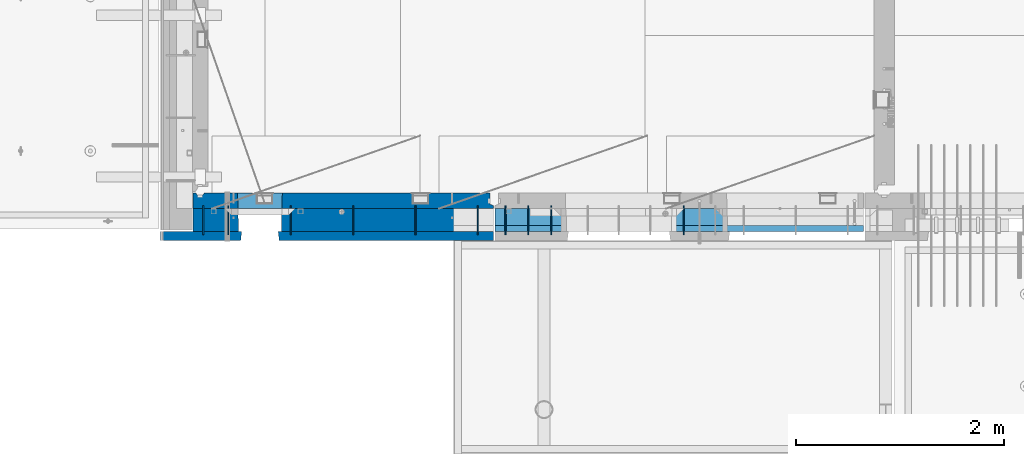
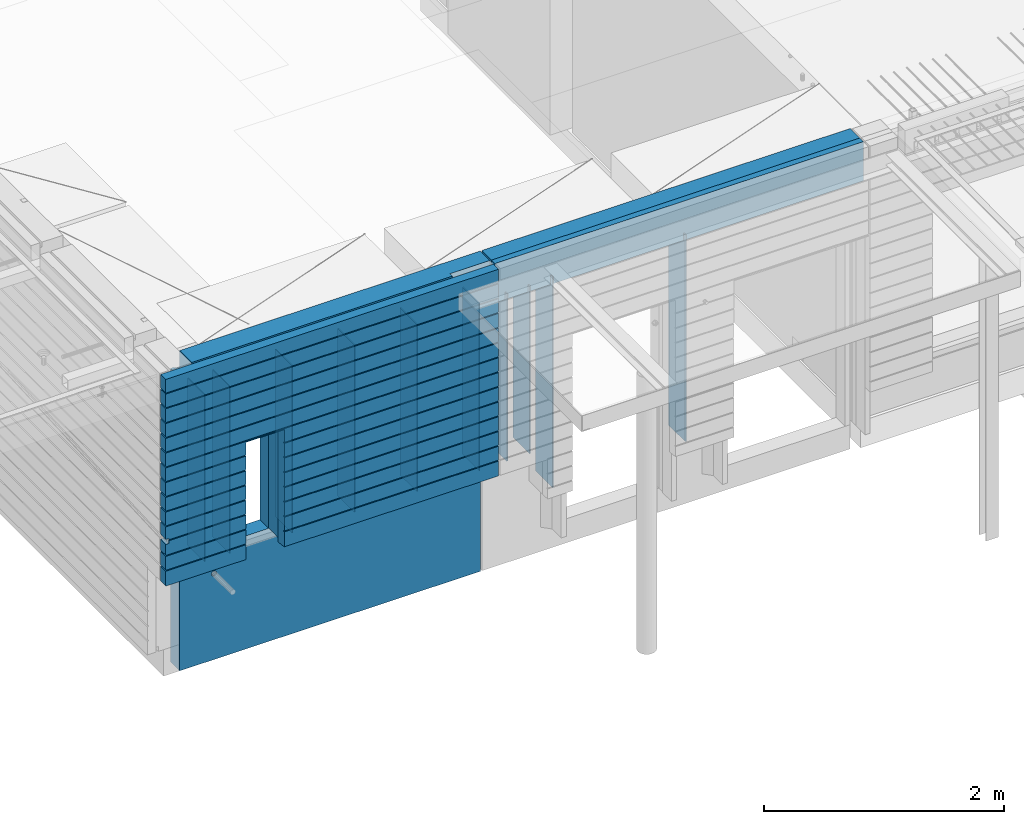
# One storey, part 206 of 325: 15 walls, 2 elements without a shape of their own.
"""IFC2X3 building model written with IfcOpenShell, lengths in millimetres."""

from ifc_helpers import new_model, si_unit, frame, origin_with_axes, place, context, subcontext, project, spatial, faceted_brep, material, type_object, element, aggregate, save


model = new_model("IFC2X3")

# Units and contexts
model_context = context("Model", 3, precision=1e-05, world=origin_with_axes())
body_context = subcontext(model_context, "Body", "Model", "MODEL_VIEW")
ifc_project = project(units=[si_unit("LENGTHUNIT", "METRE", prefix="MILLI"), si_unit("AREAUNIT", "SQUARE_METRE"), si_unit("VOLUMEUNIT", "CUBIC_METRE"), si_unit("MASSUNIT", "GRAM", prefix="KILO"), si_unit("TIMEUNIT", "SECOND"), si_unit("PLANEANGLEUNIT", "RADIAN"), si_unit("SOLIDANGLEUNIT", "STERADIAN"), si_unit("THERMODYNAMICTEMPERATUREUNIT", "DEGREE_CELSIUS"), si_unit("LUMINOUSINTENSITYUNIT", "LUMEN")], contexts=[model_context])

# Site, building, storey
site_placement = place(None, origin_with_axes())
site = spatial("IfcSite", under=ifc_project, at=site_placement, CompositionType="ELEMENT")
building_placement = place(site_placement, origin_with_axes())
building = spatial("IfcBuilding", under=site, at=building_placement, CompositionType="ELEMENT")
storey_placement = place(building_placement, origin_with_axes())
storey = spatial("IfcBuildingStorey", under=building, at=storey_placement, Name="1", CompositionType="ELEMENT", Elevation=0.0)

# Assembly, walls
assembly_1_placement = place(storey_placement, origin_with_axes())
assembly_1 = element("IfcElementAssembly", 1, at=assembly_1_placement, inside=storey, AssemblyPlace="NOTDEFINED", PredefinedType="REINFORCEMENT_UNIT")
ifc_material_1 = material(Name="COS5gt")
wall_type_1 = type_object("IfcWallType", PredefinedType="NOTDEFINED")
wall_1_placement = place(assembly_1_placement, frame((12912.5, 7740.0, 83247.5), z_axis=(0.0, 0.0, 1.0), x_axis=(-1.0, 3.00000001838171e-08, 0.0)))
wall_1 = element("IfcWall", 2, at=wall_1_placement, type_object=wall_type_1, material=ifc_material_1, context=body_context, shape_type="Brep", body=[
    faceted_brep([(392.500000000033, 90.0, 1492.5), (392.500000000033, 90.0, 1442.5), (392.500000000033, 110.0, 1442.5), (392.500000000033, 109.999999999999, 1092.50000000003), (392.500000000033, 49.9999999999991, 1092.50000000003), (392.500000000033, 49.9999999999991, 1492.50000000003), (7.50000000000728, 49.9999999999991, 1092.50000000003), (7.5, 110.0, 1092.50000000003), (7.50000000000728, 49.9999999999991, 1492.50000000003), (7.5, 90.0, -557.5), (2046.95893598611, 90.0, -557.5), (2046.95893598611, 90.0, -607.5), (7.5, 90.0, -607.5), (7.5, 110.0, -557.5), (2047.49947652665, 110.0, -557.5), (2897.5, 110.0, -557.5), (2897.5, 90.0, -557.5), (2458.04001706719, 90.0, -557.5), (2457.49947652665, 110.0, -557.5), (2897.5, 110.0, 1442.5), (2897.5, 90.0, 1442.5), (2897.5, 90.0, 1492.5), (2897.5, -110.0, 1492.5), (2897.5, -110.0, -607.5), (2897.5, 90.0, -607.5), (2458.04001706719, 90.0, -607.5), (2463.4454224726, -110.0, -607.5), (2463.4454224726, -110.0, 613.445945945947), (2457.49947652665, 110.0, 607.5), (2041.5535305807, -110.0, 613.445945945947), (2047.49947652665, 110.0, 607.5), (2041.5535305807, -110.0, -607.5), (7.5, -110.0, -607.5), (7.5, -110.0, 1492.5)], [[[0, 1, 2, 3, 4, 5]], [[6, 4, 3, 7]], [[8, 5, 4, 6]], [[9, 10, 11, 12]], [[9, 13, 14, 10]], [[15, 16, 17, 18]], [[16, 15, 19, 20, 21, 22, 23, 24]], [[17, 16, 24, 25]], [[23, 26, 25, 24]], [[27, 28, 18, 17, 25, 26]], [[29, 30, 28, 27]], [[10, 14, 30, 29, 31, 11]], [[11, 31, 32, 12]], [[29, 27, 26, 23, 22, 33, 32, 31]], [[7, 13, 9, 12, 32, 33, 8, 6]], [[2, 19, 15, 18, 28, 30, 14, 13, 7, 3]], [[20, 19, 2, 1]], [[21, 20, 1, 0]], [[33, 22, 21, 0, 5, 8]]]),
])
ifc_material_2 = material(Name="CONCRETE/C30/37")
wall_type_2 = type_object("IfcWallType", PredefinedType="NOTDEFINED")
wall_2_placement = place(assembly_1_placement, frame((12912.5, 7587.5, 83247.5), z_axis=(0.0, 0.0, 1.0), x_axis=(-1.0, 3.00000001838171e-08, 0.0)))
wall_2 = element("IfcWall", 3, at=wall_2_placement, type_object=wall_type_2, material=ifc_material_2, context=body_context, shape_type="Brep", body=[
    faceted_brep([(3207.5, -42.5, -179.98166420919), (3207.5, 42.5, -184.134200770088), (3177.5, 42.499873713009, -184.134200770088), (3177.5, -42.5, -179.98166420919), (3177.5, -42.5, -129.982527140222), (3177.5, 42.4999217833592, -134.134203897454), (3207.5, 42.5, -134.134203897454), (3207.5, -42.5, -129.982527140222), (3177.5, 42.5, -157.000000055239), (3177.5, 32.4999992501671, -155.000000000786), (3177.5, 32.4999991121649, -144.999999599575), (3177.5, 42.5, -143.000000110755), (7.4999999999709, 42.5, -457.000000055239), (2067.49947652665, 42.5, -457.000000055239), (2067.49947652665, 42.5, -607.5), (7.4999999999709, 42.5, -607.5), (7.49999999997817, 32.4999992501671, -455.000000000786), (2068.6759472031, 32.4999992501671, -455.000000000786), (7.49999999997817, 32.4999991121649, -444.999999599575), (2068.67594721934, 32.4999991121649, -444.999999599575), (7.4999999999709, 42.5, -443.000000110755), (2067.49947652665, 42.5, -443.000000110755), (7.4999999999709, 42.5, -307.000000055239), (2067.49947652665, 42.5, -307.000000055239), (7.4999999999709, 32.4999992501671, -305.000000000786), (2068.6759472031, 32.4999992501671, -305.000000000786), (7.4999999999709, 32.4999991121604, -294.999999599575), (2068.67594721934, 32.4999991121649, -294.999999599575), (7.4999999999709, 42.5, -293.000000110755), (2067.49947652665, 42.5, -293.000000110755), (7.4999999999709, 42.5, -157.000000055239), (2067.49947652665, 42.5, -157.000000055239), (7.49999999998181, 32.4999992501671, -155.000000000786), (2068.6759472031, 32.4999992501671, -155.000000000786), (7.49999999998181, 32.4999991121649, -144.999999599575), (2068.67594721934, 32.4999991121649, -144.999999599575), (7.4999999999709, 42.5, -143.000000110755), (2067.49947652665, 42.5, -143.000000110755), (7.4999999999709, 42.5, -7.00000005523907), (2067.49947652665, 42.5, -7.00000005523907), (7.4999999999709, 32.4999992501671, -5.0000000007858), (2068.6759472031, 32.4999992501671, -5.0000000007858), (7.4999999999709, 32.4999991121604, 5.00000040042505), (2068.67594721934, 32.4999991121649, 5.00000040042505), (7.4999999999709, 42.5, 6.99999988924537), (2067.49947652665, 42.5, 6.99999988924537), (7.4999999999709, 42.5, 142.999999944761), (2067.49947652665, 42.5, 142.999999944761), (7.49999999998545, 32.4999992501671, 144.999999999214), (2068.6759472031, 32.4999992501671, 144.999999999214), (7.49999999998545, 32.4999991121649, 155.000000400425), (2068.67594721934, 32.4999991121649, 155.000000400425), (7.4999999999709, 42.5, 156.999999889245), (2067.49947652665, 42.5, 156.999999889245), (7.4999999999709, 42.5, 292.999999944761), (2067.49947652665, 42.5, 292.999999944761), (7.49999999997453, 32.4999992501671, 294.999999999214), (2068.6759472031, 32.4999992501671, 294.999999999214), (7.49999999997453, 32.4999991121604, 305.000000400425), (2068.67594721934, 32.4999991121649, 305.000000400425), (7.4999999999709, 42.5, 306.999999889245), (2067.49947652665, 42.5, 306.999999889245), (7.4999999999709, 42.5, 442.999999944761), (2067.49947652665, 42.5, 442.999999944761), (7.49999999998545, 32.4999992501671, 444.999999999214), (2068.6759472031, 32.4999992501671, 444.999999999214), (7.49999999998545, 32.4999991121649, 455.000000400425), (2068.67594721934, 32.4999991121649, 455.000000400425), (7.4999999999709, 42.5, 456.999999889245), (2067.49947652665, 42.5, 456.999999889245), (7.4999999999709, 42.5, 1492.5), (3207.5, 42.5, 1492.5), (3207.5, 42.5, 1356.99999988925), (7.4999999999709, 42.5, 1356.99999988925), (7.49999999998909, 32.4999991121649, 1355.00000040043), (3197.4999991143, 32.4999991121649, 1355.00000040043), (7.49999999998909, 32.4999992501671, 1344.99999999921), (3197.4999992523, 32.4999992501671, 1344.99999999921), (7.4999999999709, 42.5, 1342.99999994476), (3207.5, 42.5, 1342.99999994476), (3207.5, 42.5, 1206.99999988925), (7.4999999999709, 42.5, 1206.99999988925), (7.49999999998363, 32.4999991121604, 1205.00000040043), (3197.49999897767, 32.4999991121604, 1205.00000040043), (7.49999999998363, 32.4999992501671, 1194.99999999921), (3197.49999925687, 32.4999992501671, 1194.99999999921), (7.4999999999709, 42.5, 1192.99999994476), (3207.5, 42.5, 1192.99999994476), (3207.5, 42.5, 1056.99999988925), (7.4999999999709, 42.5, 1056.99999988925), (7.49999999998727, 32.4999991121649, 1055.00000040043), (3197.4999991143, 32.4999991121649, 1055.00000040043), (7.49999999998727, 32.4999992501671, 1044.99999999921), (3197.4999992523, 32.4999992501671, 1044.99999999921), (7.4999999999709, 42.5, 1042.99999994476), (3207.5, 42.5, 1042.99999994476), (3207.5, 42.5, 906.999999889245), (7.4999999999709, 42.5, 906.999999889245), (7.49999999998181, 32.4999991121604, 905.000000400425), (3197.49999897767, 32.4999991121604, 905.000000400425), (7.49999999998181, 32.4999992501671, 894.999999999214), (3197.49999925687, 32.4999992501671, 894.999999999214), (7.4999999999709, 42.5, 892.999999944761), (3207.5, 42.5, 892.999999944761), (3207.5, 42.5, 756.999999889245), (7.4999999999709, 42.5, 756.999999889245), (7.49999999998727, 32.4999991121649, 755.000000400425), (3197.4999991143, 32.4999991121649, 755.000000400425), (7.49999999998727, 32.4999992501671, 744.999999999214), (3197.4999992523, 32.4999992501671, 744.999999999214), (7.4999999999709, 42.5, 742.999999944761), (3207.5, 42.5, 742.999999944761), (3207.5, 42.5, 606.999999889245), (7.4999999999709, 42.5, 606.999999889245), (7.49999999997999, 32.4999991121604, 605.000000400425), (3197.49999897767, 32.4999991121604, 605.000000400425), (7.49999999997999, 32.4999992501671, 594.999999999214), (3197.49999925687, 32.4999992501671, 594.999999999214), (7.4999999999709, 42.5, 592.999999944761), (3207.5, 42.5, 592.999999944761), (3207.5, 42.5, 456.999999889245), (2437.49947652665, 42.5, 456.999999889245), (2437.49947652665, 42.5, 582.5), (2427.49947652665, 42.5, 582.5), (2077.49947652665, 42.5, 582.5), (2067.49947652665, 42.5, 582.5), (2436.32300583397, 32.4999991121649, 455.000000400425), (3197.4999991143, 32.4999991121649, 455.000000400425), (2436.3230058502, 32.4999992501671, 444.999999999214), (3197.4999992523, 32.4999992501671, 444.999999999214), (2437.49947652665, 42.5, 442.999999944761), (3207.5, 42.5, 442.999999944761), (3207.5, 42.5, 306.999999889245), (2437.49947652665, 42.5, 306.999999889245), (2436.32300583397, 32.4999991121649, 305.000000400425), (3197.49999897767, 32.4999991121604, 305.000000400425), (2436.3230058502, 32.4999992501671, 294.999999999214), (3197.49999925687, 32.4999992501671, 294.999999999214), (2437.49947652665, 42.5, 292.999999944761), (3207.5, 42.5, 292.999999944761), (3207.5, 42.5, 156.999999889245), (2437.49947652665, 42.5, 156.999999889245), (2436.32300583397, 32.4999991121649, 155.000000400425), (3197.4999991143, 32.4999991121649, 155.000000400425), (2436.3230058502, 32.4999992501671, 144.999999999214), (3197.4999992523, 32.4999992501671, 144.999999999214), (2437.49947652665, 42.5, 142.999999944761), (3207.5, 42.5, 142.999999944761), (3207.5, 42.5, 6.99999988924537), (2437.49947652665, 42.5, 6.99999988924537), (2436.32300583397, 32.4999991121649, 5.00000040042505), (3197.49999897767, 32.4999991121604, 5.00000040042505), (2436.3230058502, 32.4999992501671, -5.0000000007858), (3197.49999925687, 32.4999992501671, -5.0000000007858), (2437.49947652665, 42.5, -7.00000005523907), (3207.5, 42.5, -7.00000005523907), (2437.49947652665, 42.5, -457.000000055239), (3207.5, 42.5, -457.000000055239), (3207.5, 42.5, -607.5), (2437.49947652665, 42.5, -607.5), (2436.3230058502, 32.4999992501671, -455.000000000786), (3197.4999992523, 32.4999992501671, -455.000000000786), (2436.32300583397, 32.4999991121649, -444.999999599575), (3197.4999991143, 32.4999991121649, -444.999999599575), (2437.49947652665, 42.5, -443.000000110755), (3207.5, 42.5, -443.000000110755), (3207.5, 42.5, -307.000000055239), (2437.49947652665, 42.5, -307.000000055239), (2436.3230058502, 32.4999992501671, -305.000000000786), (3197.49999925687, 32.4999992501671, -305.000000000786), (2436.32300583397, 32.4999991121649, -294.999999599575), (3197.49999897767, 32.4999991121604, -294.999999599575), (2437.49947652665, 42.5, -293.000000110755), (3207.5, 42.5, -293.000000110755), (3197.49999368253, -42.5, -294.999998542233), (3207.5, -42.5, -292.999998912201), (3197.49999396174, -42.5, -304.999998943444), (3207.5, -42.5, -306.9999988567), (3207.5, -42.5, -443.00000011074), (3197.4999991143, -42.5, -444.999999599546), (3197.4999992523, -42.5, -455.000000000771), (3207.5, -42.5, -457.000000055225), (3207.5, -42.5, -607.5), (2427.49947652665, -42.5, -607.5), (2427.49947652665, -42.5, 582.5), (2427.49947652665, -42.5, 587.5), (2437.49947652665, 42.5, -143.000000110755), (2436.32300583397, 32.4999991121649, -144.999999599575), (2436.3230058502, 32.4999992501671, -155.000000000786), (2437.49947652665, 42.5, -157.000000055239), (2077.49947652665, -42.5, 587.5), (2077.49947652665, -42.5, 582.5), (2077.49947652665, -42.5, -607.5), (7.4999999999709, -42.5, -607.5), (7.4999999999709, -42.5, 1492.5), (3207.5, -42.5, 1492.5), (3207.5, -42.5, 1356.99999988926), (3197.4999991143, -42.5, 1355.00000040045), (3197.4999992523, -42.5, 1344.99999999923), (3207.5, -42.5, 1342.99999994478), (3207.5, -42.5, 1207.0000010878), (3197.49999368253, -42.5, 1205.00000145777), (3197.49999396174, -42.5, 1195.00000105656), (3207.5, -42.5, 1193.0000011433), (3207.5, -42.5, 1056.99999988926), (3197.4999991143, -42.5, 1055.00000040045), (3197.4999992523, -42.5, 1044.99999999923), (3207.5, -42.5, 1042.99999994478), (3207.5, -42.5, 907.000001087799), (3197.49999368253, -42.5, 905.000001457767), (3197.49999396174, -42.5, 895.000001056556), (3207.5, -42.5, 893.0000011433), (3207.5, -42.5, 756.99999988926), (3197.4999991143, -42.5, 755.000000400454), (3197.4999992523, -42.5, 744.999999999229), (3207.5, -42.5, 742.999999944775), (3207.5, -42.5, 607.000001087799), (3197.49999368253, -42.5, 605.000001457767), (3197.49999396174, -42.5, 595.000001056556), (3207.5, -42.5, 593.0000011433), (3207.5, -42.5, 456.99999988926), (3197.4999991143, -42.5, 455.000000400454), (3197.4999992523, -42.5, 444.999999999229), (3207.5, -42.5, 442.999999944775), (3207.5, -42.5, 307.000001087799), (3197.49999368253, -42.5, 305.000001457767), (3197.49999396174, -42.5, 295.000001056556), (3207.5, -42.5, 293.0000011433), (3207.5, -42.5, 156.99999988926), (3197.4999991143, -42.5, 155.000000400454), (3197.4999992523, -42.5, 144.999999999229), (3207.5, -42.5, 142.999999944775), (3207.5, -42.5, 7.00000108779932), (3197.49999368253, -42.5, 5.00000145776721), (3197.49999396174, -42.5, -4.99999894344364), (3207.5, -42.5, -6.99999885669968)], [[[0, 1, 2, 3]], [[4, 5, 6, 7]], [[3, 2, 8, 9, 10, 11, 5, 4]], [[12, 13, 14, 15]], [[12, 16, 17, 13]], [[16, 18, 19, 17]], [[18, 20, 21, 19]], [[20, 22, 23, 21]], [[22, 24, 25, 23]], [[24, 26, 27, 25]], [[26, 28, 29, 27]], [[28, 30, 31, 29]], [[30, 32, 33, 31]], [[32, 34, 35, 33]], [[34, 36, 37, 35]], [[36, 38, 39, 37]], [[38, 40, 41, 39]], [[40, 42, 43, 41]], [[42, 44, 45, 43]], [[44, 46, 47, 45]], [[46, 48, 49, 47]], [[48, 50, 51, 49]], [[50, 52, 53, 51]], [[52, 54, 55, 53]], [[54, 56, 57, 55]], [[56, 58, 59, 57]], [[58, 60, 61, 59]], [[60, 62, 63, 61]], [[62, 64, 65, 63]], [[64, 66, 67, 65]], [[66, 68, 69, 67]], [[70, 71, 72, 73]], [[74, 73, 72, 75]], [[76, 74, 75, 77]], [[78, 76, 77, 79]], [[80, 81, 78, 79]], [[82, 81, 80, 83]], [[84, 82, 83, 85]], [[86, 84, 85, 87]], [[86, 87, 88, 89]], [[90, 89, 88, 91]], [[92, 90, 91, 93]], [[94, 92, 93, 95]], [[96, 97, 94, 95]], [[98, 97, 96, 99]], [[100, 98, 99, 101]], [[102, 100, 101, 103]], [[102, 103, 104, 105]], [[106, 105, 104, 107]], [[108, 106, 107, 109]], [[110, 108, 109, 111]], [[112, 113, 110, 111]], [[114, 113, 112, 115]], [[116, 114, 115, 117]], [[118, 116, 117, 119]], [[68, 118, 119, 120, 121, 122, 123, 124, 125, 69]], [[126, 121, 120, 127]], [[128, 126, 127, 129]], [[130, 128, 129, 131]], [[131, 132, 133, 130]], [[134, 133, 132, 135]], [[136, 134, 135, 137]], [[138, 136, 137, 139]], [[139, 140, 141, 138]], [[142, 141, 140, 143]], [[144, 142, 143, 145]], [[146, 144, 145, 147]], [[147, 148, 149, 146]], [[150, 149, 148, 151]], [[152, 150, 151, 153]], [[154, 152, 153, 155]], [[156, 157, 158, 159]], [[156, 160, 161, 157]], [[160, 162, 163, 161]], [[162, 164, 165, 163]], [[166, 165, 164, 167]], [[167, 168, 169, 166]], [[168, 170, 171, 169]], [[170, 172, 173, 171]], [[174, 171, 173, 175]], [[176, 169, 171, 174]], [[177, 166, 169, 176]], [[178, 165, 166, 177]], [[179, 163, 165, 178]], [[180, 161, 163, 179]], [[181, 157, 161, 180]], [[182, 158, 157, 181]], [[158, 182, 183, 159]], [[184, 185, 122, 121, 126, 128, 130, 133, 134, 136, 138, 141, 142, 144, 146, 149, 150, 152, 154, 186, 187, 188, 189, 172, 170, 168, 167, 164, 162, 160, 156, 159, 183]], [[124, 123, 122, 185, 190, 125]], [[13, 17, 19, 21, 23, 25, 27, 29, 31, 33, 35, 37, 39, 41, 43, 45, 47, 49, 51, 53, 55, 57, 59, 61, 63, 65, 67, 69, 125, 190, 191, 192, 14]], [[14, 192, 193, 15]], [[194, 70, 73, 74, 76, 78, 81, 82, 84, 86, 89, 90, 92, 94, 97, 98, 100, 102, 105, 106, 108, 110, 113, 114, 116, 118, 68, 66, 64, 62, 60, 58, 56, 54, 52, 50, 48, 46, 44, 42, 40, 38, 36, 34, 32, 30, 28, 26, 24, 22, 20, 18, 16, 12, 15, 193]], [[70, 194, 195, 71]], [[71, 195, 196, 72]], [[197, 75, 72, 196]], [[198, 77, 75, 197]], [[199, 79, 77, 198]], [[200, 80, 79, 199]], [[201, 83, 80, 200]], [[202, 85, 83, 201]], [[203, 87, 85, 202]], [[204, 88, 87, 203]], [[205, 91, 88, 204]], [[206, 93, 91, 205]], [[207, 95, 93, 206]], [[208, 96, 95, 207]], [[209, 99, 96, 208]], [[210, 101, 99, 209]], [[211, 103, 101, 210]], [[212, 104, 103, 211]], [[213, 107, 104, 212]], [[214, 109, 107, 213]], [[215, 111, 109, 214]], [[216, 112, 111, 215]], [[217, 115, 112, 216]], [[218, 117, 115, 217]], [[219, 119, 117, 218]], [[220, 120, 119, 219]], [[221, 127, 120, 220]], [[222, 129, 127, 221]], [[223, 131, 129, 222]], [[224, 132, 131, 223]], [[225, 135, 132, 224]], [[226, 137, 135, 225]], [[227, 139, 137, 226]], [[228, 140, 139, 227]], [[229, 143, 140, 228]], [[230, 145, 143, 229]], [[231, 147, 145, 230]], [[232, 148, 147, 231]], [[233, 151, 148, 232]], [[234, 153, 151, 233]], [[235, 155, 153, 234]], [[155, 235, 7, 6]], [[186, 154, 155, 6, 5, 11]], [[187, 186, 11, 10]], [[188, 187, 10, 9]], [[189, 188, 9, 8]], [[1, 173, 172, 189, 8, 2]], [[175, 173, 1, 0]], [[235, 234, 233, 232, 231, 230, 229, 228, 227, 226, 225, 224, 223, 222, 221, 220, 219, 218, 217, 216, 215, 214, 213, 212, 211, 210, 209, 208, 207, 206, 205, 204, 203, 202, 201, 200, 199, 198, 197, 196, 195, 194, 193, 192, 191, 190, 185, 184, 183, 182, 181, 180, 179, 178, 177, 176, 174, 175, 0, 3, 4, 7]]]),
])

assembly_2_placement = place(storey_placement, origin_with_axes())
assembly_2 = element("IfcElementAssembly", 4, at=assembly_2_placement, inside=storey, AssemblyPlace="NOTDEFINED", PredefinedType="REINFORCEMENT_UNIT")
ifc_material_3 = material(Name="Undefined")
wall_type_3 = type_object("IfcWallType", PredefinedType="NOTDEFINED")
wall_3_placement = place(assembly_2_placement, frame((13460.0, 7880.0, 83365.0), z_axis=(0.0, 0.0, 1.0), x_axis=(0.0, -1.0, 0.0)))
wall_3 = element("IfcWall", 5, at=wall_3_placement, type_object=wall_type_3, material=ifc_material_3, Name="(PD)", context=body_context, shape_type="Brep", body=[
    faceted_brep([(0.0, 5.0, -1070.0), (0.0, 5.0, 1070.0), (280.0, 5.0, 1070.0), (280.0, 5.0, -1070.0), (0.0, -5.0, 1070.0), (280.0, -5.0, 1070.0), (0.0, -5.0, -1070.0), (280.0, -5.0, -1070.0)], [[[0, 1, 2, 3]], [[1, 4, 5, 2]], [[4, 6, 7, 5]], [[6, 0, 3, 7]], [[5, 7, 3, 2]], [[6, 4, 1, 0]]]),
])
wall_type_4 = type_object("IfcWallType", PredefinedType="NOTDEFINED")
wall_4_placement = place(assembly_2_placement, frame((13240.0, 7880.0, 83565.0), z_axis=(0.0, 0.0, 1.0), x_axis=(0.0, -1.0, 0.0)))
wall_4 = element("IfcWall", 6, at=wall_4_placement, type_object=wall_type_4, material=ifc_material_3, Name="(PD)", context=body_context, shape_type="Brep", body=[
    faceted_brep([(0.0, 5.0, -850.0), (0.0, 5.0, 850.0), (280.0, 5.0, 850.0), (280.0, 5.0, -850.0), (0.0, -5.0, 850.0), (280.0, -5.0, 850.0), (0.0, -5.0, -850.0), (280.0, -5.0, -850.0)], [[[0, 1, 2, 3]], [[1, 4, 5, 2]], [[4, 6, 7, 5]], [[6, 0, 3, 7]], [[5, 7, 3, 2]], [[6, 4, 1, 0]]]),
])

# Wall
wall_5_placement = place(assembly_1_placement, frame((10115.0, 7880.0, 83560.0), z_axis=(0.0, 0.0, 1.0), x_axis=(0.0, -1.0, 0.0)))
wall_5 = element("IfcWall", 7, at=wall_5_placement, type_object=wall_type_4, material=ifc_material_3, Name="(PD)", context=body_context, shape_type="Brep", body=[
    faceted_brep([(0.0, 5.0, -850.0), (0.0, 5.0, 850.0), (280.0, 5.0, 850.0), (280.0, 5.0, -850.0), (0.0, -5.0, 850.0), (280.0, -5.0, 850.0), (0.0, -5.0, -850.0), (280.0, -5.0, -850.0)], [[[0, 1, 2, 3]], [[1, 4, 5, 2]], [[4, 6, 7, 5]], [[6, 0, 3, 7]], [[5, 7, 3, 2]], [[6, 4, 1, 0]]]),
])

wall_6_placement = place(assembly_1_placement, frame((10355.0, 7880.0, 83560.0), z_axis=(0.0, 0.0, 1.0), x_axis=(0.0, -1.0, 0.0)))
wall_6 = element("IfcWall", 8, at=wall_6_placement, type_object=wall_type_4, material=ifc_material_3, Name="(PD)", context=body_context, shape_type="Brep", body=[
    faceted_brep([(0.0, 5.0, -850.0), (0.0, 5.0, 850.0), (280.0, 5.0, 850.0), (280.0, 5.0, -850.0), (0.0, -5.0, 850.0), (280.0, -5.0, 850.0), (0.0, -5.0, -850.0), (280.0, -5.0, -850.0)], [[[0, 1, 2, 3]], [[1, 4, 5, 2]], [[4, 6, 7, 5]], [[6, 0, 3, 7]], [[5, 7, 3, 2]], [[6, 4, 1, 0]]]),
])

wall_7_placement = place(assembly_1_placement, frame((10955.0, 7880.0, 83560.0), z_axis=(0.0, 0.0, 1.0), x_axis=(0.0, -1.0, 0.0)))
wall_7 = element("IfcWall", 9, at=wall_7_placement, type_object=wall_type_4, material=ifc_material_3, Name="(PD)", context=body_context, shape_type="Brep", body=[
    faceted_brep([(0.0, 5.0, -850.0), (0.0, 5.0, 850.0), (280.0, 5.0, 850.0), (280.0, 5.0, -850.0), (0.0, -5.0, 850.0), (280.0, -5.0, 850.0), (0.0, -5.0, -850.0), (280.0, -5.0, -850.0)], [[[0, 1, 2, 3]], [[1, 4, 5, 2]], [[4, 6, 7, 5]], [[6, 0, 3, 7]], [[5, 7, 3, 2]], [[6, 4, 1, 0]]]),
])

wall_8_placement = place(assembly_1_placement, frame((11555.0, 7880.0, 83560.0), z_axis=(0.0, 0.0, 1.0), x_axis=(0.0, -1.0, 0.0)))
wall_8 = element("IfcWall", 10, at=wall_8_placement, type_object=wall_type_4, material=ifc_material_3, Name="(PD)", context=body_context, shape_type="Brep", body=[
    faceted_brep([(0.0, 5.0, -850.0), (0.0, 5.0, 850.0), (280.0, 5.0, 850.0), (280.0, 5.0, -850.0), (0.0, -5.0, 850.0), (280.0, -5.0, 850.0), (0.0, -5.0, -850.0), (280.0, -5.0, -850.0)], [[[0, 1, 2, 3]], [[1, 4, 5, 2]], [[4, 6, 7, 5]], [[6, 0, 3, 7]], [[5, 7, 3, 2]], [[6, 4, 1, 0]]]),
])

wall_9_placement = place(assembly_1_placement, frame((12155.0, 7880.0, 83560.0), z_axis=(0.0, 0.0, 1.0), x_axis=(0.0, -1.0, 0.0)))
wall_9 = element("IfcWall", 11, at=wall_9_placement, type_object=wall_type_4, material=ifc_material_3, Name="(PD)", context=body_context, shape_type="Brep", body=[
    faceted_brep([(0.0, 5.0, -850.0), (0.0, 5.0, 850.0), (280.0, 5.0, 850.0), (280.0, 5.0, -850.0), (0.0, -5.0, 850.0), (280.0, -5.0, 850.0), (0.0, -5.0, -850.0), (280.0, -5.0, -850.0)], [[[0, 1, 2, 3]], [[1, 4, 5, 2]], [[4, 6, 7, 5]], [[6, 0, 3, 7]], [[5, 7, 3, 2]], [[6, 4, 1, 0]]]),
])

wall_10_placement = place(assembly_2_placement, frame((13020.0, 7880.0, 83565.0), z_axis=(0.0, 0.0, 1.0), x_axis=(0.0, -1.0, 0.0)))
wall_10 = element("IfcWall", 12, at=wall_10_placement, type_object=wall_type_4, material=ifc_material_3, Name="(PD)", context=body_context, shape_type="Brep", body=[
    faceted_brep([(0.0, 5.0, -850.0), (0.0, 5.0, 850.0), (280.0, 5.0, 850.0), (280.0, 5.0, -850.0), (0.0, -5.0, 850.0), (280.0, -5.0, 850.0), (0.0, -5.0, -850.0), (280.0, -5.0, -850.0)], [[[0, 1, 2, 3]], [[1, 4, 5, 2]], [[4, 6, 7, 5]], [[6, 0, 3, 7]], [[5, 7, 3, 2]], [[6, 4, 1, 0]]]),
])

wall_11_placement = place(assembly_1_placement, frame((12755.0, 7880.0, 83560.0), z_axis=(0.0, 0.0, 1.0), x_axis=(0.0, -1.0, 0.0)))
wall_11 = element("IfcWall", 13, at=wall_11_placement, type_object=wall_type_4, material=ifc_material_3, Name="(PD)", context=body_context, shape_type="Brep", body=[
    faceted_brep([(0.0, 5.0, -850.0), (0.0, 5.0, 850.0), (280.0, 5.0, 850.0), (280.0, 5.0, -850.0), (0.0, -5.0, 850.0), (280.0, -5.0, 850.0), (0.0, -5.0, -850.0), (280.0, -5.0, -850.0)], [[[0, 1, 2, 3]], [[1, 4, 5, 2]], [[4, 6, 7, 5]], [[6, 0, 3, 7]], [[5, 7, 3, 2]], [[6, 4, 1, 0]]]),
])

ifc_material_4 = material(Name="CONCRETE/C25/30")
wall_type_5 = type_object("IfcWallType", PredefinedType="NOTDEFINED")
wall_12_placement = place(assembly_1_placement, frame((12912.5, 7925.0, 82977.5), z_axis=(0.0, 0.0, 1.0), x_axis=(-1.0, 3.00000001838171e-08, 0.0)))
wall_12 = element("IfcWall", 14, at=wall_12_placement, type_object=wall_type_5, material=ifc_material_4, context=body_context, shape_type="Brep", body=[
    faceted_brep([(2800.5, -55.0, -1225.0), (2800.5, -55.0, -1492.5), (2802.5, -55.0, -1492.5), (2802.5, -55.0, -1225.0), (2787.5, -75.0, -1225.0), (2787.5, -75.0, -1492.5), (2854.5, -55.0, -1225.0), (2854.5, -55.0, -1492.5), (2867.5, -75.0, -1492.5), (2867.5, -75.0, -1225.0), (2852.5, -55.0, -1225.0), (2852.5, -55.0, -1492.5), (7.5, 75.0, 1492.5), (7.5, 75.0, -1492.5), (7.5, 45.0, -1492.5), (7.5, 45.0, 1492.5), (40.0, -75.0, 1492.5), (40.0, 32.0, 1492.5), (40.0, 32.0, -1492.5), (40.0, -75.0, -1492.5), (2787.5, -75.0, 1492.5), (2800.5, -55.0, 1492.5), (2854.5, -55.0, 1492.5), (2867.5, -75.0, 1492.5), (2897.5, -75.0, 1492.5), (2897.5, 75.0, 1492.5), (2787.5, -75.0, 1231.5), (2787.5, -75.0, 1225.0), (2800.5, -55.0, 1225.0), (2854.5, -55.0, 1225.0), (2867.5, -75.0, 1225.0), (2867.5, -75.0, 1231.5), (2897.5, -75.0, -1492.5), (2897.5, 75.0, -1492.5), (2467.49947652665, -75.0, -347.5), (2463.4454224726, 75.0, -343.445945945947), (2041.5535305807, 75.0, -343.445945945947), (2037.49947652665, -75.0, -347.5), (2467.49947652665, -75.0, 887.5), (2463.4454224726, 75.0, 883.445945945947), (2037.49947652665, -75.0, 887.5), (2041.5535305807, 75.0, 883.445945945947), (2549.14056777503, 75.0, -635.177669529658), (2557.25115149557, 75.0, -640.596988312784), (2566.81823730469, 75.0, -642.5), (2576.38532311382, 75.0, -640.596988312784), (2584.49590683436, 75.0, -635.177669529658), (2589.91522561748, 75.0, -627.067085809133), (2591.81823730469, 75.0, -617.5), (2589.91522561748, 75.0, -607.932914190867), (2584.49590683436, 75.0, -599.822330470342), (2576.38532311382, 75.0, -594.403011687216), (2566.81823730469, 75.0, -592.5), (2557.25115149557, 75.0, -594.403011687216), (2549.14056777503, 75.0, -599.822330470342), (2543.72124899191, 75.0, -607.932914190867), (2541.81823730469, 75.0, -617.5), (2543.72124899191, 75.0, -627.067085809133), (2543.72124899191, -75.0, -627.067085809133), (2541.81823730469, -75.0, -617.5), (2549.14056777503, -75.0, -635.177669529658), (2557.25115149557, -75.0, -640.596988312784), (2566.81823730469, -75.0, -642.5), (2576.38532311382, -75.0, -640.596988312784), (2584.49590683436, -75.0, -635.177669529658), (2589.91522561748, -75.0, -627.067085809133), (2591.81823730469, -75.0, -617.5), (2589.91522561748, -75.0, -607.932914190867), (2584.49590683436, -75.0, -599.822330470342), (2576.38532311382, -75.0, -594.403011687216), (2566.81823730469, -75.0, -592.5), (2557.25115149557, -75.0, -594.403011687216), (2549.14056777503, -75.0, -599.822330470342), (2543.72124899191, -75.0, -607.932914190867)], [[[0, 1, 2, 3]], [[4, 5, 1, 0]], [[6, 7, 8, 9]], [[10, 11, 7, 6]], [[12, 13, 14, 15]], [[16, 17, 18, 19]], [[15, 14, 18, 17]], [[16, 20, 21, 22, 23, 24, 25, 12, 15, 17]], [[20, 26, 27, 4, 0, 28, 21]], [[21, 28, 0, 3, 10, 6, 29, 22]], [[22, 29, 6, 9, 30, 31, 23]], [[32, 24, 23, 31, 30, 9, 8]], [[24, 32, 33, 25]], [[34, 35, 36, 37]], [[35, 34, 38, 39]], [[40, 41, 39, 38]], [[37, 36, 41, 40]], [[13, 12, 25, 33], [42, 43, 44, 45, 46, 47, 48, 49, 50, 51, 52, 53, 54, 55, 56, 57], [35, 39, 41, 36]], [[58, 57, 56, 59]], [[60, 42, 57, 58]], [[61, 43, 42, 60]], [[62, 44, 43, 61]], [[63, 45, 44, 62]], [[64, 46, 45, 63]], [[65, 47, 46, 64]], [[66, 48, 47, 65]], [[67, 49, 48, 66]], [[68, 50, 49, 67]], [[69, 51, 50, 68]], [[70, 52, 51, 69]], [[71, 53, 52, 70]], [[72, 54, 53, 71]], [[73, 55, 54, 72]], [[59, 56, 55, 73]], [[27, 26, 20, 16, 19, 5, 4], [72, 71, 70, 69, 68, 67, 66, 65, 64, 63, 62, 61, 60, 58, 59, 73], [34, 37, 40, 38]], [[19, 18, 14, 13, 33, 32, 8, 7, 11, 2, 1, 5]], [[3, 2, 11, 10]]]),
])

aggregate(assembly_1, [wall_5, wall_6, wall_7, wall_8, wall_9, wall_11, wall_2, wall_1, wall_12])

ifc_material_5 = material(Name="SPU")
wall_type_6 = type_object("IfcWallType", PredefinedType="NOTDEFINED")
wall_13_placement = place(assembly_2_placement, frame((16460.0000000001, 7770.0, 84540.0), z_axis=(0.0, 0.0, 1.0), x_axis=(-1.0, 3.00000001838171e-08, 0.0)))
wall_13 = element("IfcWall", 15, at=wall_13_placement, type_object=wall_type_6, material=ifc_material_5, context=body_context, shape_type="Brep", body=[
    faceted_brep([(0.0, 80.0, -200.0), (0.0, 80.0, 200.0), (3540.00000000004, 80.0, 200.0), (3540.00000000004, 80.0, -200.0), (0.0, -80.0, 200.0), (3540.00000000004, -80.0, 200.0), (0.0, -80.0, -200.0), (3540.00000000004, -80.0, -200.0)], [[[0, 1, 2, 3]], [[1, 4, 5, 2]], [[4, 6, 7, 5]], [[6, 0, 3, 7]], [[5, 7, 3, 2]], [[6, 4, 1, 0]]]),
])

wall_type_7 = type_object("IfcWallType", PredefinedType="NOTDEFINED")
wall_14_placement = place(assembly_2_placement, frame((16460.0, 7660.0, 84540.0), z_axis=(0.0, 0.0, 1.0), x_axis=(-1.0, 3.00000001838171e-08, 0.0)))
wall_14 = element("IfcWall", 16, at=wall_14_placement, type_object=wall_type_7, material=ifc_material_2, context=body_context, shape_type="Brep", body=[
    faceted_brep([(0.0, 30.0, -200.0), (0.0, 30.0, 200.0), (3540.00000000003, 30.0, 200.0), (3540.00000000003, 30.0, -200.0), (0.0, -30.0, 200.0), (3540.00000000003, -30.0, 200.0), (0.0, -30.0, -200.0), (3540.00000000003, -30.0, -200.0)], [[[0, 1, 2, 3]], [[1, 4, 5, 2]], [[4, 6, 7, 5]], [[6, 0, 3, 7]], [[5, 7, 3, 2]], [[6, 4, 1, 0]]]),
])

wall_type_8 = type_object("IfcWallType", PredefinedType="NOTDEFINED")
wall_15_placement = place(assembly_2_placement, frame((14735.0, 7880.0, 83365.0), z_axis=(0.0, 0.0, 1.0), x_axis=(0.0, -1.0, 0.0)))
wall_15 = element("IfcWall", 17, at=wall_15_placement, type_object=wall_type_8, material=ifc_material_3, Name="(PD)", context=body_context, shape_type="Brep", body=[
    faceted_brep([(0.0, 5.0, -1050.0), (0.0, 5.0, 1050.0), (280.0, 5.0, 1050.0), (280.0, 5.0, -1050.0), (0.0, -5.0, 1050.0), (280.0, -5.0, 1050.0), (0.0, -5.0, -1050.0), (280.0, -5.0, -1050.0)], [[[0, 1, 2, 3]], [[1, 4, 5, 2]], [[4, 6, 7, 5]], [[6, 0, 3, 7]], [[5, 7, 3, 2]], [[6, 4, 1, 0]]]),
])

aggregate(assembly_2, [wall_3, wall_4, wall_10, wall_15, wall_13, wall_14])

save(model, "model.ifc")
